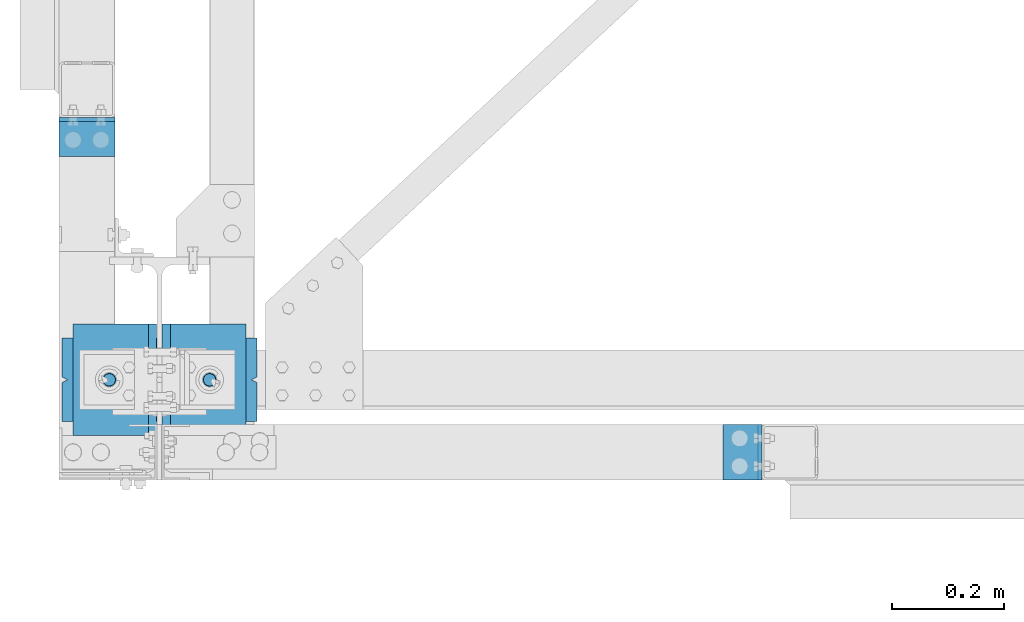
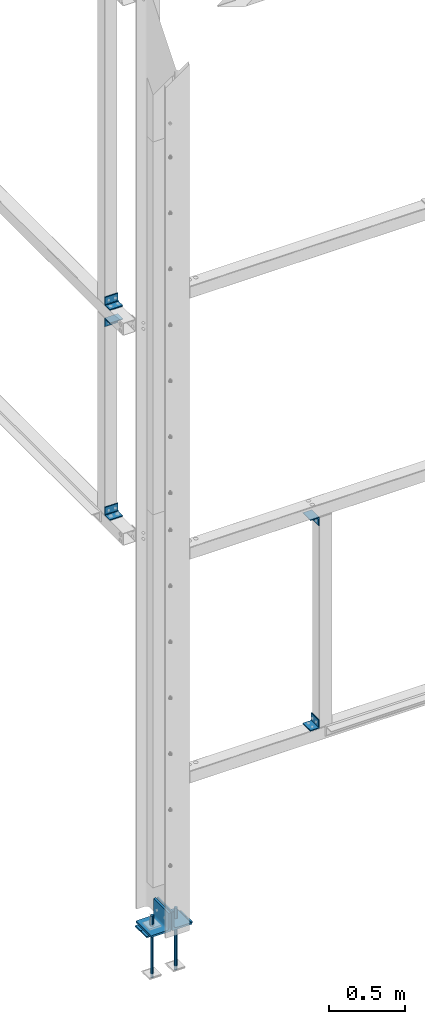
# One storey, part 61 of 496: 12 beams, 8 elements without a shape of their own.
"""IFC2X3 building model written with IfcOpenShell, lengths in millimetres."""

from ifc_helpers import new_model, si_unit, frame, origin_with_axes, origin_2d_with_axis, place, context, subcontext, project, spatial, polyline, rectangle, circle, l_section, outline, extrude, boolean, material, type_object, element, aggregate, save


model = new_model("IFC2X3")

# Units and contexts
model_context = context("Model", 3, precision=1e-05, world=origin_with_axes())
body_context = subcontext(model_context, "Body", "Model", "MODEL_VIEW")
ifc_project = project(units=[si_unit("LENGTHUNIT", "METRE", prefix="MILLI"), si_unit("AREAUNIT", "SQUARE_METRE"), si_unit("VOLUMEUNIT", "CUBIC_METRE"), si_unit("MASSUNIT", "GRAM", prefix="KILO"), si_unit("TIMEUNIT", "SECOND"), si_unit("PLANEANGLEUNIT", "RADIAN"), si_unit("SOLIDANGLEUNIT", "STERADIAN"), si_unit("THERMODYNAMICTEMPERATUREUNIT", "DEGREE_CELSIUS"), si_unit("LUMINOUSINTENSITYUNIT", "LUMEN")], contexts=[model_context])

# Site, building, storey
site_placement = place(None, origin_with_axes())
site = spatial("IfcSite", under=ifc_project, at=site_placement, CompositionType="ELEMENT")
building_placement = place(site_placement, origin_with_axes())
building = spatial("IfcBuilding", under=site, at=building_placement, Name="Undefined", CompositionType="ELEMENT")
storey_placement = place(building_placement, origin_with_axes())
storey = spatial("IfcBuildingStorey", under=building, at=storey_placement, Name="Undefined", CompositionType="ELEMENT", Elevation=0.0)

# Assembly, beam
assembly_1_placement = place(storey_placement, origin_with_axes())
assembly_1 = element("IfcElementAssembly", 1, at=assembly_1_placement, inside=storey, AssemblyPlace="NOTDEFINED", PredefinedType="NOTDEFINED")
ifc_material = material(Name="Undefined/S235-E24")
beam_type_1 = type_object("IfcBeamType", PredefinedType="NOTDEFINED")
beam_1_placement = place(assembly_1_placement, frame((-80.0000075420904, 434.993396912366, 4584.99997777166), z_axis=(0.0, -1.0, 0.0), x_axis=(-1.0, 0.0, 0.0)))
beam_1 = element("IfcBeam", 2, at=beam_1_placement, type_object=beam_type_1, material=ifc_material, context=body_context, shape_type="SweptSolid", body=[
    extrude(l_section(Depth=70.0, Width=70.0, Thickness=7.0, FilletRadius=9.0, EdgeRadius=4.5, at=origin_2d_with_axis()), frame((100.000000000021, 5.72981662116945e-11, -4.09272615797818e-12), z_axis=(-1.0, 0.0, 0.0), x_axis=(0.0, -1.0, 0.0)), (0.0, 0.0, 1.0), 100.0),
])
aggregate(assembly_1, [beam_1])

assembly_2_placement = place(storey_placement, origin_with_axes())
assembly_2 = element("IfcElementAssembly", 3, at=assembly_2_placement, inside=storey, AssemblyPlace="NOTDEFINED", PredefinedType="NOTDEFINED")
beam_2_placement = place(assembly_2_placement, frame((-80.0000075420904, 434.993383392366, 2894.99997765688), z_axis=(0.0, -1.0, 0.0), x_axis=(-1.0, 0.0, 0.0)))
beam_2 = element("IfcBeam", 4, at=beam_2_placement, type_object=beam_type_1, material=ifc_material, context=body_context, shape_type="SweptSolid", body=[
    extrude(l_section(Depth=70.0, Width=70.0, Thickness=7.0, FilletRadius=9.0, EdgeRadius=4.5, at=origin_2d_with_axis()), frame((100.000000000021, 5.72981662116945e-11, -4.09272615797818e-12), z_axis=(-1.0, 0.0, 0.0), x_axis=(0.0, -1.0, 0.0)), (0.0, 0.0, 1.0), 100.0),
])
aggregate(assembly_2, [beam_2])

assembly_3_placement = place(storey_placement, origin_with_axes())
assembly_3 = element("IfcElementAssembly", 5, at=assembly_3_placement, inside=storey, AssemblyPlace="NOTDEFINED", PredefinedType="NOTDEFINED")
beam_3_placement = place(assembly_3_placement, frame((-179.999995944303, 434.993382392367, 4415.00002234312), z_axis=(0.0, -1.0, 0.0), x_axis=(1.0, 0.0, 0.0)))
beam_3 = element("IfcBeam", 6, at=beam_3_placement, type_object=beam_type_1, material=ifc_material, context=body_context, shape_type="SweptSolid", body=[
    extrude(l_section(Depth=70.0, Width=70.0, Thickness=7.0, FilletRadius=9.0, EdgeRadius=4.5, at=origin_2d_with_axis()), frame((100.000000000021, 5.72981662116945e-11, -4.09272615797818e-12), z_axis=(-1.0, 0.0, 0.0), x_axis=(0.0, -1.0, 0.0)), (0.0, 0.0, 1.0), 100.0),
])
aggregate(assembly_3, [beam_3])

assembly_4_placement = place(storey_placement, origin_with_axes())
assembly_4 = element("IfcElementAssembly", 7, at=assembly_4_placement, inside=storey, AssemblyPlace="NOTDEFINED", PredefinedType="NOTDEFINED")
beam_4_placement = place(assembly_4_placement, frame((1045.000000969, -180.000008614613, 2765.0), z_axis=(0.0, 0.0, -1.0), x_axis=(0.0, 1.0, 0.0)))
beam_4 = element("IfcBeam", 8, at=beam_4_placement, type_object=beam_type_1, material=ifc_material, context=body_context, shape_type="SweptSolid", body=[
    extrude(l_section(Depth=70.0, Width=70.0, Thickness=7.0, FilletRadius=9.0, EdgeRadius=4.5, at=origin_2d_with_axis()), frame((100.000000000021, 5.72981662116945e-11, -4.09272615797818e-12), z_axis=(-1.0, 0.0, 0.0), x_axis=(0.0, -1.0, 0.0)), (0.0, 0.0, 1.0), 100.0),
])
aggregate(assembly_4, [beam_4])

assembly_5_placement = place(storey_placement, origin_with_axes())
assembly_5 = element("IfcElementAssembly", 9, at=assembly_5_placement, inside=storey, AssemblyPlace="NOTDEFINED", PredefinedType="NOTDEFINED")
beam_5_placement = place(assembly_5_placement, frame((1044.999999969, -80.0000086005748, 1135.0), z_axis=(0.0, 0.0, 1.0), x_axis=(0.0, -1.0, 0.0)))
beam_5 = element("IfcBeam", 10, at=beam_5_placement, type_object=beam_type_1, material=ifc_material, context=body_context, shape_type="SweptSolid", body=[
    extrude(l_section(Depth=70.0, Width=70.0, Thickness=7.0, FilletRadius=9.0, EdgeRadius=4.5, at=origin_2d_with_axis()), frame((100.000000000021, 5.72981662116945e-11, -4.09272615797818e-12), z_axis=(-1.0, 0.0, 0.0), x_axis=(0.0, -1.0, 0.0)), (0.0, 0.0, 1.0), 100.0),
])
aggregate(assembly_5, [beam_5])

# Assembly, beams
assembly_6_placement = place(storey_placement, origin_with_axes())
assembly_6 = element("IfcElementAssembly", 11, at=assembly_6_placement, inside=storey, Name="PS24", AssemblyPlace="NOTDEFINED", PredefinedType="NOTDEFINED")
beam_type_2 = type_object("IfcBeamType", Name="D24", PredefinedType="NOTDEFINED")
beam_6_placement = place(assembly_6_placement, frame((-90.0028495552906, 0.0, -100.0), z_axis=(0.0, 1.0, 0.0), x_axis=(0.0, 0.0, -1.0)))
beam_6 = element("IfcBeam", 12, at=beam_6_placement, type_object=beam_type_2, material=ifc_material, ObjectType="D24", context=body_context, shape_type="SweptSolid", body=[
    extrude(circle(Radius=12.0, at=origin_2d_with_axis()), frame((149.999995982835, 4.54747350886464e-12, 3.63797880709171e-12), z_axis=(-1.0, 0.0, 0.0), x_axis=(0.0, -1.0, 0.0)), (0.0, 0.0, 1.0), 150.0),
])
beam_7_placement = place(assembly_6_placement, frame((89.9971504447094, 0.0, -100.0), z_axis=(0.0, 1.0, 0.0), x_axis=(0.0, 0.0, -1.0)))
beam_7 = element("IfcBeam", 13, at=beam_7_placement, type_object=beam_type_2, material=ifc_material, ObjectType="D24", context=body_context, shape_type="SweptSolid", body=[
    extrude(circle(Radius=12.0, at=origin_2d_with_axis()), frame((149.999995982835, 4.54747350886464e-12, 3.63797880709171e-12), z_axis=(-1.0, 0.0, 0.0), x_axis=(0.0, -1.0, 0.0)), (0.0, 0.0, 1.0), 150.0),
])
beam_type_3 = type_object("IfcBeamType", Name="D22", PredefinedType="NOTDEFINED")
beam_8_placement = place(assembly_6_placement, frame((-90.0028495552906, 0.0, -250.0), z_axis=(0.0, 1.0, 0.0), x_axis=(0.0, 0.0, -1.0)))
beam_8 = element("IfcBeam", 14, at=beam_8_placement, type_object=beam_type_3, material=ifc_material, ObjectType="D22", context=body_context, shape_type="SweptSolid", body=[
    extrude(circle(Radius=11.0, at=origin_2d_with_axis()), frame((350.0, 0.0, 0.0), z_axis=(-1.0, 0.0, 0.0), x_axis=(0.0, -1.0, 0.0)), (0.0, 0.0, 1.0), 350.0),
])
beam_9_placement = place(assembly_6_placement, frame((89.9971504447094, 0.0, -250.0), z_axis=(0.0, 1.0, 0.0), x_axis=(0.0, 0.0, -1.0)))
beam_9 = element("IfcBeam", 15, at=beam_9_placement, type_object=beam_type_3, material=ifc_material, ObjectType="D22", context=body_context, shape_type="SweptSolid", body=[
    extrude(circle(Radius=11.0, at=origin_2d_with_axis()), frame((350.0, 0.0, 0.0), z_axis=(-1.0, 0.0, 0.0), x_axis=(0.0, -1.0, 0.0)), (0.0, 0.0, 1.0), 350.0),
])
beam_type_4 = type_object("IfcBeamType", PredefinedType="NOTDEFINED")
beam_10_placement = place(assembly_6_placement, frame((175.0, 0.0, -205.0), z_axis=(0.0, -1.0, 0.0), x_axis=(-1.0, 0.0, 0.0)))
beam_10 = element("IfcBeam", 16, at=beam_10_placement, type_object=beam_type_4, material=ifc_material, Name="PS24", context=body_context, shape_type="CSG", body=[
    boolean("DIFFERENCE", boolean("DIFFERENCE", boolean("DIFFERENCE", boolean("DIFFERENCE", extrude(rectangle(XDim=10.0, YDim=150.0, at=origin_2d_with_axis()), frame((350.0, 0.0, 0.0), z_axis=(-1.0, 0.0, 0.0), x_axis=(0.0, -1.0, 0.0)), (0.0, 0.0, 1.0), 350.0), extrude(outline(polyline([(0.0, 0.0), (11.1803398132297, 1.2732925824821e-11), (4.47213602066586, 8.94427204135718), (0.0, 0.0)])), frame((0.0, 7.5, -5.0), z_axis=(0.0, -1.0, 0.0), x_axis=(0.894427191199935, 0.0, 0.44721359509992)), (0.0, 0.0, 1.0), 15.0)), extrude(outline(polyline([(0.0, 0.0), (11.1803398132297, 1.2732925824821e-11), (4.47213602066586, 8.94427204135718), (0.0, 0.0)])), frame((180.0, 7.5, -75.0), z_axis=(0.0, -1.0, 0.0), x_axis=(-0.447213595099959, 0.0, 0.894427191199915)), (0.0, 0.0, 1.0), 15.0)), extrude(outline(polyline([(0.0, 0.0), (11.1803398132297, 1.2732925824821e-11), (6.70820379256475, 8.94427204134627), (0.0, 0.0)])), frame((340.0, 7.5, 0.0), z_axis=(0.0, -1.0, 0.0), x_axis=(0.894427191199935, 0.0, -0.44721359509992)), (0.0, 0.0, 1.0), 15.0)), extrude(outline(polyline([(0.0, 0.0), (11.1803398132297, 1.2732925824821e-11), (4.47213602066586, 8.94427204135718), (0.0, 0.0)])), frame((170.0, 7.5, 75.0), z_axis=(0.0, -1.0, 0.0), x_axis=(0.447213595099959, 0.0, -0.894427191199915)), (0.0, 0.0, 1.0), 15.0)),
])
aggregate(assembly_6, [beam_6, beam_8, beam_7, beam_9, beam_10])

# Assembly, beam
assembly_7_placement = place(storey_placement, origin_with_axes())
assembly_7 = element("IfcElementAssembly", 17, at=assembly_7_placement, inside=storey, AssemblyPlace="NOTDEFINED", PredefinedType="NOTDEFINED")
beam_type_5 = type_object("IfcBeamType", PredefinedType="NOTDEFINED")
beam_11_placement = place(assembly_7_placement, frame((-80.0028495552906, 100.0, -125.0), z_axis=(0.0, 0.0, 1.0), x_axis=(0.0, -1.0, 0.0)))
beam_11 = element("IfcBeam", 18, at=beam_11_placement, type_object=beam_type_5, material=ifc_material, context=body_context, shape_type="SweptSolid", body=[
    extrude(l_section(Depth=150.0, Width=150.0, Thickness=15.0, FilletRadius=16.0, EdgeRadius=8.0, at=origin_2d_with_axis()), frame((200.0, 0.0, 0.0), z_axis=(-1.0, 0.0, 0.0), x_axis=(0.0, -1.0, 0.0)), (0.0, 0.0, 1.0), 200.0),
])
aggregate(assembly_7, [beam_11])

assembly_8_placement = place(storey_placement, origin_with_axes())
assembly_8 = element("IfcElementAssembly", 19, at=assembly_8_placement, inside=storey, AssemblyPlace="NOTDEFINED", PredefinedType="NOTDEFINED")
beam_12_placement = place(assembly_8_placement, frame((79.9971504447094, -100.0, -125.0), z_axis=(0.0, 0.0, 1.0), x_axis=(0.0, 1.0, 0.0)))
beam_12 = element("IfcBeam", 20, at=beam_12_placement, type_object=beam_type_5, material=ifc_material, context=body_context, shape_type="SweptSolid", body=[
    extrude(l_section(Depth=150.0, Width=150.0, Thickness=15.0, FilletRadius=16.0, EdgeRadius=8.0, at=origin_2d_with_axis()), frame((200.0, 0.0, 0.0), z_axis=(-1.0, 0.0, 0.0), x_axis=(0.0, -1.0, 0.0)), (0.0, 0.0, 1.0), 200.0),
])
aggregate(assembly_8, [beam_12])

save(model, "model.ifc")
